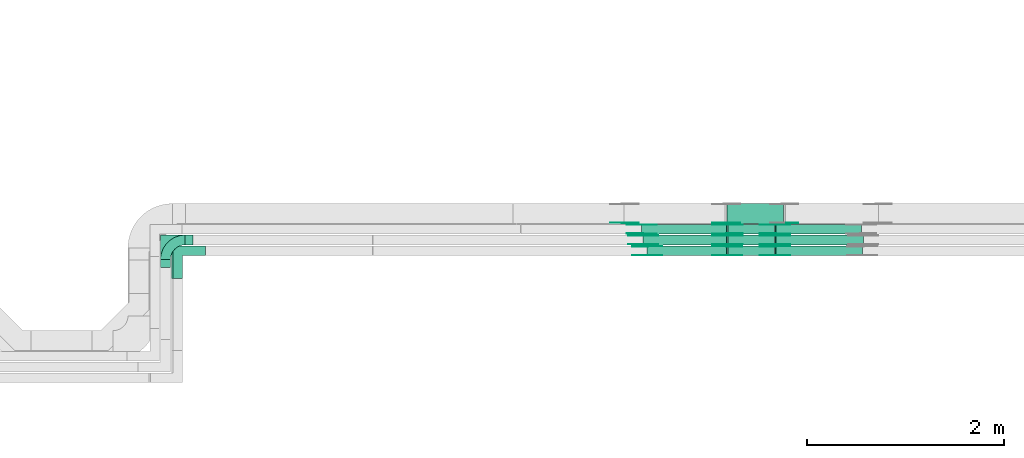
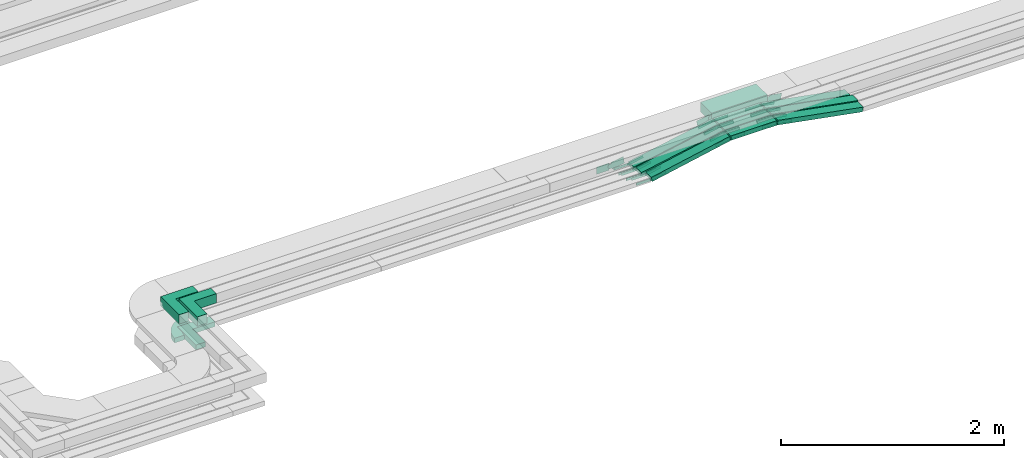
# One storey, part 21 of 33: 45 flow fittings, 10 flow segments.
"""IFC2X3 building model written with IfcOpenShell, lengths in millimetres."""

from ifc_helpers import new_model, entity, si_unit, converted_unit, derived_unit, direction, frame, frame_2d, origin, origin_2d_with_axis, place, context, subcontext, project, spatial, polyline, circle_curve, parameter, trimmed, segment, composite_curve, rectangle, outline, extrude, source, transform, mapped, material, type_object, type_shapes, element, save


model = new_model("IFC2X3")

# Units and contexts
model_context = context("Model", 3, precision=0.01, world=origin(), true_north=direction((6.12303176911189e-17, 1.0)))
body_context = subcontext(model_context, "Body", "Model", "MODEL_VIEW")
ifc_project = project(units=[si_unit("LENGTHUNIT", "METRE", prefix="MILLI"), si_unit("AREAUNIT", "SQUARE_METRE"), si_unit("VOLUMEUNIT", "CUBIC_METRE"), converted_unit("PLANEANGLEUNIT", "DEGREE", entity("IfcRatioMeasure", 0.0174532925199433), si_unit("PLANEANGLEUNIT", "RADIAN"), dimensions=[0, 0, 0, 0, 0, 0, 0]), si_unit("MASSUNIT", "GRAM", prefix="KILO"), derived_unit("MASSDENSITYUNIT", [(si_unit("MASSUNIT", "GRAM", prefix="KILO"), 1), (si_unit("LENGTHUNIT", "METRE"), -3)]), derived_unit("MOMENTOFINERTIAUNIT", [(si_unit("LENGTHUNIT", "METRE"), 4)]), si_unit("TIMEUNIT", "SECOND"), si_unit("FREQUENCYUNIT", "HERTZ"), si_unit("THERMODYNAMICTEMPERATUREUNIT", "DEGREE_CELSIUS"), derived_unit("THERMALTRANSMITTANCEUNIT", [(si_unit("MASSUNIT", "GRAM", prefix="KILO"), 1), (si_unit("THERMODYNAMICTEMPERATUREUNIT", "KELVIN"), -1), (si_unit("TIMEUNIT", "SECOND"), -3)]), derived_unit("VOLUMETRICFLOWRATEUNIT", [(si_unit("LENGTHUNIT", "METRE"), 3), (si_unit("TIMEUNIT", "SECOND"), -1)]), derived_unit("MASSFLOWRATEUNIT", [(si_unit("MASSUNIT", "GRAM", prefix="KILO"), 1), (si_unit("TIMEUNIT", "SECOND"), -1)]), derived_unit("ROTATIONALFREQUENCYUNIT", [(si_unit("TIMEUNIT", "SECOND"), -1)]), si_unit("ELECTRICCURRENTUNIT", "AMPERE"), si_unit("ELECTRICVOLTAGEUNIT", "VOLT"), si_unit("POWERUNIT", "WATT"), si_unit("FORCEUNIT", "NEWTON", prefix="KILO"), si_unit("ILLUMINANCEUNIT", "LUX"), si_unit("LUMINOUSFLUXUNIT", "LUMEN"), si_unit("LUMINOUSINTENSITYUNIT", "CANDELA"), derived_unit("USERDEFINED", [(si_unit("MASSUNIT", "GRAM", prefix="KILO"), -1), (si_unit("LENGTHUNIT", "METRE"), -2), (si_unit("TIMEUNIT", "SECOND"), 3), (si_unit("LUMINOUSFLUXUNIT", "LUMEN"), 1)]), derived_unit("LINEARVELOCITYUNIT", [(si_unit("LENGTHUNIT", "METRE"), 1), (si_unit("TIMEUNIT", "SECOND"), -1)]), si_unit("PRESSUREUNIT", "PASCAL"), derived_unit("USERDEFINED", [(si_unit("LENGTHUNIT", "METRE"), -2), (si_unit("MASSUNIT", "GRAM", prefix="KILO"), 1), (si_unit("TIMEUNIT", "SECOND"), -2)]), derived_unit("LINEARFORCEUNIT", [(si_unit("MASSUNIT", "GRAM", prefix="KILO"), 1), (si_unit("LENGTHUNIT", "METRE"), 1), (si_unit("TIMEUNIT", "SECOND"), -2), (si_unit("LENGTHUNIT", "METRE"), -1)]), derived_unit("PLANARFORCEUNIT", [(si_unit("MASSUNIT", "GRAM", prefix="KILO"), 1), (si_unit("LENGTHUNIT", "METRE"), 1), (si_unit("TIMEUNIT", "SECOND"), -2), (si_unit("LENGTHUNIT", "METRE"), -2)])], contexts=[model_context])

# Site, building, storey
site_placement = place(None, frame((0.0, -0.00077364408347762, 0.0)))
site = spatial("IfcSite", under=ifc_project, at=site_placement, CompositionType="ELEMENT")
building_placement = place(site_placement, origin())
building = spatial("IfcBuilding", under=site, at=building_placement, CompositionType="ELEMENT")
storey_placement = place(building_placement, frame((0.0, 0.0, 8100.0)))
storey = spatial("IfcBuildingStorey", under=building, at=storey_placement, CompositionType="ELEMENT", Elevation=8100.0)

# Flow segments
cable_carrier_segment_type = type_object("IfcCableCarrierSegmentType", PredefinedType="CABLETRAYSEGMENT")
flow_segment_1_placement = place(storey_placement, frame((50660.6410134739, 9694.9989777832, 2713.30497735665)))
element("IfcFlowSegment", 1, at=flow_segment_1_placement, inside=storey, type_object=cable_carrier_segment_type, context=body_context, shape_type="SweptSolid", body=[
    extrude(rectangle(XDim=477.273522129145, YDim=100.000000000001, at=frame_2d((0.0, 5.40012479177676e-13), x_axis=(1.0, 0.0))), frame((238.636913060613, 50.0015440115957, 0.000818588273602927)), (0.0, 0.0, 1.0), 50.0000000000017),
])
flow_segment_2_placement = place(storey_placement, frame((50650.9575491214, 10024.9993759154, 2713.61173786445)))
element("IfcFlowSegment", 2, at=flow_segment_2_placement, inside=storey, type_object=cable_carrier_segment_type, context=body_context, shape_type="SweptSolid", body=[
    extrude(rectangle(XDim=577.431980396776, YDim=199.999999999998, at=frame_2d((4.32009983342141e-12, 0.0), x_axis=(1.0, 0.0))), frame((288.715990198384, 100.0, 0.0)), (0.0, 0.0, 1.0), 99.9999999999989),
])
flow_segment_3_placement = place(storey_placement, frame((50662.4382699219, 9914.99937591541, 2713.31163055766)))
element("IfcFlowSegment", 3, at=flow_segment_3_placement, inside=storey, type_object=cable_carrier_segment_type, context=body_context, shape_type="SweptSolid", body=[
    extrude(rectangle(XDim=475.291800517506, YDim=99.9999999999989, at=origin_2d_with_axis()), frame((237.645900258753, 50.0, 0.0)), (0.0, 0.0, 1.0), 50.0000000000016),
])
flow_segment_4_placement = place(storey_placement, frame((50661.2573309693, 9804.99937591543, 2713.54019628628)))
element("IfcFlowSegment", 4, at=flow_segment_4_placement, inside=storey, type_object=cable_carrier_segment_type, context=body_context, shape_type="SweptSolid", body=[
    extrude(rectangle(XDim=476.37052042903, YDim=99.9999999999989, at=origin_2d_with_axis()), frame((238.185260214515, 50.0, 0.0), z_axis=(0.0, 0.0, 1.0), x_axis=(-1.0, 0.0, 0.0)), (0.0, 0.0, 1.0), 50.0000000000016),
])
flow_segment_5_placement = place(storey_placement, frame((49839.4010757259, 9695.00046998201, 2547.96021925731)))
element("IfcFlowSegment", 5, at=flow_segment_5_placement, inside=storey, type_object=cable_carrier_segment_type, context=body_context, shape_type="SweptSolid", body=[
    extrude(rectangle(XDim=50.0000000000023, YDim=100.000000000001, at=frame_2d((0.0, 5.43565192856477e-13), x_axis=(1.0, 0.0))), frame((5.00126271690856, 50.00037989648, 24.4954151198667), z_axis=(0.979786827050049, 0.0, 0.200044428913172), x_axis=(-0.200044428890075, 1.51960900459464e-05, 0.979786826936922)), (0.0, 0.0, 1.0), 825.136376037674),
])
flow_segment_6_placement = place(storey_placement, frame((51140.6281172227, 9694.99937591542, 2549.41535615934)))
element("IfcFlowSegment", 6, at=flow_segment_6_placement, inside=storey, type_object=cable_carrier_segment_type, context=body_context, shape_type="SweptSolid", body=[
    extrude(rectangle(XDim=50.0000000000012, YDim=100.000000000001, at=frame_2d((0.0, -1.08357767203415e-12), x_axis=(1.0, 0.0))), frame((4.56396664450065, 50.0, 188.220535018025), z_axis=(0.983194962125325, 0.0, -0.182558665780022), x_axis=(0.182558665780022, 0.0, 0.983194962125325)), (0.0, 0.0, 1.0), 896.373011194787),
])
flow_segment_7_placement = place(storey_placement, frame((49799.866783238, 9804.99937591543, 2547.51129297495)))
element("IfcFlowSegment", 7, at=flow_segment_7_placement, inside=storey, type_object=cable_carrier_segment_type, context=body_context, shape_type="SweptSolid", body=[
    extrude(rectangle(XDim=49.9999999999987, YDim=99.9999999999989, at=origin_2d_with_axis()), frame((4.79033535033332, 50.0, 24.5367619548982), z_axis=(0.981470478195865, 0.0, 0.191613414013684), x_axis=(-0.191613414013684, 0.0, 0.981470478195865)), (0.0, 0.0, 1.0), 865.091688195415),
])
flow_segment_8_placement = place(storey_placement, frame((51140.327569371, 9804.99937591543, 2551.08518892179)))
element("IfcFlowSegment", 8, at=flow_segment_8_placement, inside=storey, type_object=cable_carrier_segment_type, context=body_context, shape_type="SweptSolid", body=[
    extrude(rectangle(XDim=50.0000000000008, YDim=99.9999999999989, at=frame_2d((0.0, 0.0), x_axis=(0.0, 1.0))), frame((4.47414157658034, 50.0, 186.807845992506), z_axis=(0.983855320382255, 0.0, -0.178965663062864), x_axis=(0.0, 1.0, 0.0)), (0.0, 0.0, 1.0), 906.383158684558),
])
flow_segment_9_placement = place(storey_placement, frame((49784.864005538, 9914.99937591541, 2546.09274625035)))
element("IfcFlowSegment", 9, at=flow_segment_9_placement, inside=storey, type_object=cable_carrier_segment_type, context=body_context, shape_type="SweptSolid", body=[
    extrude(rectangle(XDim=50.0000000000003, YDim=99.9999999999989, at=origin_2d_with_axis()), frame((4.7359862940918, 50.0, 24.547310113782), z_axis=(0.981892404551273, 0.0, 0.189439451763671), x_axis=(-0.189439451763671, 0.0, 0.981892404551273)), (0.0, 0.0, 1.0), 881.321250243893),
])
flow_segment_10_placement = place(storey_placement, frame((51140.4451131751, 9914.99937591541, 2550.9680207194)))
element("IfcFlowSegment", 10, at=flow_segment_10_placement, inside=storey, type_object=cable_carrier_segment_type, context=body_context, shape_type="SweptSolid", body=[
    extrude(rectangle(XDim=50.0000000000006, YDim=99.9999999999989, at=frame_2d((0.0, 0.0), x_axis=(0.0, 1.0))), frame((4.57453998484662, 50.0, 186.671002044407), z_axis=(0.983116338122434, 0.0, -0.182981599393862), x_axis=(0.0, 1.0, 0.0)), (0.0, 0.0, 1.0), 885.843681158498),
])

# Flow fittings
ifc_material_1 = material()
cable_carrier_fitting_type_1 = type_object("IfcCableCarrierFittingType", Name="470_DKC_F5_Mesh horizontal angle:At right angles", PredefinedType="NOTDEFINED", material=ifc_material_1)
shared_shape_1 = source(origin(), body_context, "Body", "SweptSolid", [
    extrude(outline(polyline([(-143.333333333335, -143.333333333332), (186.666666666646, -143.333333333332), (186.666666666652, -43.3333333333317), (-43.3333333333294, -43.3333333333373), (-43.3333333333166, 186.666666666663), (-143.333333333317, 186.666666666669), (-143.333333333335, -143.333333333332)])), frame((-93.3333333333341, 93.3333333333192, -25.0), z_axis=(0.0, 0.0, 1.0), x_axis=(0.0, 1.0, 0.0)), (0.0, 0.0, 1.0), 51.9999999999999),
])
type_shapes(cable_carrier_fitting_type_1, [shared_shape_1])
flow_fitting_1_placement = place(storey_placement, frame((45049.8958236255, 9745.00084987847, 2571.66940793271), z_axis=(0.0, 0.0, 1.0), x_axis=(-1.0, 0.0, 0.0)))
element("IfcFlowFitting", 11, at=flow_fitting_1_placement, inside=storey, type_object=cable_carrier_fitting_type_1, material=ifc_material_1, Name="470_DKC_F5_Mesh horizontal angle:At right angles", ObjectType="470_DKC_F5_Mesh horizontal angle:At right angles", context=body_context, shape_type="MappedRepresentation", body=[
    mapped(shared_shape_1, transform((0.0, 0.0, 0.0), scale=1.0)),
])
cable_carrier_fitting_type_2 = type_object("IfcCableCarrierFittingType", Name="470_DKC_F5_Mesh horizontal angle:At right angles", PredefinedType="NOTDEFINED", material=ifc_material_1)
shared_shape_2 = source(origin(), body_context, "Body", "SweptSolid", [
    extrude(outline(polyline([(-143.333333333335, -143.333333333332), (186.666666666646, -143.333333333332), (186.666666666652, -43.3333333333317), (-43.3333333333294, -43.3333333333373), (-43.3333333333166, 186.666666666663), (-143.333333333317, 186.666666666669), (-143.333333333335, -143.333333333332)])), frame((-93.3333333333341, 93.3333333333192, -50.0), z_axis=(0.0, 0.0, 1.0), x_axis=(0.0, 1.0, 0.0)), (0.0, 0.0, 1.0), 102.0),
])
type_shapes(cable_carrier_fitting_type_2, [shared_shape_2])
for number, where, z_axis, x_axis, name in (
    (12, (44939.3895051674, 9854.99937591543, 2850.01096864734), (2.17578588737003e-05, 0.0, 1.0), (-1.0, 0.0, 2.17578588737003e-05), "470_DKC_F5_Mesh horizontal angle:At right angles"),
    (13, (45064.8958232878, 9745.00067454254, 2849.2813532093), (4.69987070140133e-07, 0.0, 1.0), (-1.0, 0.0, 4.69987070140133e-07), "470_DKC_F5_Mesh horizontal angle:At right angles"),
):
    element("IfcFlowFitting", number, at=place(storey_placement, frame(where, z_axis=z_axis, x_axis=x_axis)), inside=storey, type_object=cable_carrier_fitting_type_2, material=ifc_material_1, Name=name, ObjectType="470_DKC_F5_Mesh horizontal angle:At right angles", context=body_context, shape_type="MappedRepresentation", body=[
        mapped(shared_shape_2, transform((0.0, 0.0, 0.0), scale=1.0)),
    ])
cable_carrier_fitting_type_3 = type_object("IfcCableCarrierFittingType", Name="470_DKC_S5_Variable Angle Elbow 0-45:-", PredefinedType="NOTDEFINED", material=ifc_material_1)
shared_shape_3 = source(origin(), body_context, "Body", "SweptSolid", [
    extrude(outline(composite_curve([segment(polyline([(-100.750000000001, -150.25), (-99.7499999999994, -150.25)]), True, "CONTINUOUS"), segment(trimmed(circle_curve(frame_2d((-99.7499999999997, 99.7499999999995), x_axis=(0.0, -1.0)), 250.0), [parameter(0.0)], [parameter(90.0000000000001)], True, "PARAMETER"), True, "CONTINUOUS"), segment(polyline([(150.25, 99.75), (150.25, 100.749999999999)]), True, "CONTINUOUS"), segment(polyline([(150.25, 100.749999999999), (50.25, 100.75)]), True, "CONTINUOUS"), segment(polyline([(50.25, 100.75), (50.25, 99.7499999999998)]), True, "CONTINUOUS"), segment(trimmed(circle_curve(frame_2d((-99.7499999999997, 99.7499999999995), x_axis=(0.0, -1.0)), 150.0), [parameter(0.0)], [parameter(90.0000000000001)], True, "PARAMETER"), False, "CONTINUOUS"), segment(polyline([(-99.7499999999994, -50.2500000000003), (-100.750000000001, -50.2500000000003)]), True, "CONTINUOUS"), segment(polyline([(-100.750000000001, -50.2500000000003), (-100.750000000001, -150.25)]), True, "CONTINUOUS")], self_intersect=False)), frame((-100.249999999991, 100.249999999992, -25.0)), (0.0, 0.0, 1.0), 49.9999999999997),
])
type_shapes(cable_carrier_fitting_type_3, [shared_shape_3])
flow_fitting_2_placement = place(storey_placement, frame((44939.3895051674, 9854.99937591542, 2571.31908538351), z_axis=(0.0, 0.0, 1.0), x_axis=(-1.0, 0.0, 0.0)))
element("IfcFlowFitting", 14, at=flow_fitting_2_placement, inside=storey, type_object=cable_carrier_fitting_type_3, material=ifc_material_1, Name="470_DKC_S5_Variable Angle Elbow 0-45:-", ObjectType="470_DKC_S5_Variable Angle Elbow 0-45:-", context=body_context, shape_type="MappedRepresentation", body=[
    mapped(shared_shape_3, transform((0.0, 0.0, 0.0), scale=1.0)),
])
ifc_material_2 = material(Name="G")
cable_carrier_fitting_type_4 = type_object("IfcCableCarrierFittingType", PredefinedType="NOTDEFINED", material=ifc_material_2)
shared_shape_4 = source(origin(), body_context, "Body", "SweptSolid", [
    extrude(outline(composite_curve([segment(trimmed(circle_curve(frame_2d((-44.5901162790698, 0.0), x_axis=(1.0, 0.0)), 12.5), [parameter(90.0000000000007)], [parameter(270.0)], True, "PARAMETER"), True, "CONTINUOUS"), segment(polyline([(-44.5901162790697, -12.5), (-33.0901162790698, -12.5)]), True, "CONTINUOUS"), segment(polyline([(-33.0901162790698, -12.5), (-31.2296511627907, -14.5)]), True, "CONTINUOUS"), segment(polyline([(-31.2296511627907, -14.5), (108.90988372093, -14.5)]), True, "CONTINUOUS"), segment(polyline([(108.90988372093, -14.5), (108.90988372093, 14.5)]), True, "CONTINUOUS"), segment(polyline([(108.90988372093, 14.5), (-31.2296511627907, 14.5)]), True, "CONTINUOUS"), segment(polyline([(-31.2296511627907, 14.5), (-33.0901162790698, 12.5)]), True, "CONTINUOUS"), segment(polyline([(-33.0901162790698, 12.5), (-44.5901162790699, 12.5)]), True, "CONTINUOUS")], self_intersect=False)), frame((44.5901162790698, 0.0, 0.0), z_axis=(0.0, 0.0, -1.0), x_axis=(1.0, 0.0, 0.0)), (0.0, 0.0, -1.0), 2.0),
])
type_shapes(cable_carrier_fitting_type_4, [shared_shape_4])
for number, where, z_axis, x_axis in (
    (15, (49840.5515223138, 9699.54084986832, 2571.6694079327), (0.0, -1.0, 0.0), (0.979786827050029, 0.0, 0.200044428913269)),
    (16, (50656.7107681397, 9699.54084987357, 2738.3064727923), (-3.03989314942444e-06, -1.0, 1.48889288550001e-05), (-0.979786827054556, 0.0, -0.200044428891096)),
    (17, (51141.584357233, 9790.45937591928, 2738.30654020205), (3.03989318177189e-06, 1.0, 1.63717654735008e-05), (0.983194962125356, 0.0, -0.182558665779853)),
    (18, (50657.4529545895, 9809.53937590527, 2738.54019628629), (0.0, -1.0, 0.0), (-0.981470478195842, 0.0, -0.191613414013801)),
    (19, (49800.9232354835, 9809.53937590527, 2571.3190853835), (0.0, -1.0, 0.0), (0.981470478195842, 0.0, 0.191613414013801)),
    (20, (51141.243971725, 9900.45937592559, 2738.54019628629), (0.0, 1.0, 0.0), (0.983855320382267, 0.0, -0.178965663062798)),
    (21, (50658.6663010256, 9919.53937590525, 2738.31163055767), (0.0, -1.0, 0.0), (-0.9818924045513, 0.0, -0.189439451763528)),
    (22, (49785.8963242226, 9919.53937590525, 2569.92549664433), (0.0, -1.0, 0.0), (0.9818924045513, 0.0, 0.189439451763528)),
    (23, (51141.4058924678, 10010.4593759256, 2738.31163055767), (0.0, 1.0, 0.0), (0.98311633812243, 0.0, -0.182981599393884)),
):
    element("IfcFlowFitting", number, at=place(storey_placement, frame(where, z_axis=z_axis, x_axis=x_axis)), inside=storey, type_object=cable_carrier_fitting_type_4, material=ifc_material_2, context=body_context, shape_type="MappedRepresentation", body=[
        mapped(shared_shape_4, transform((0.0, 0.0, 0.0), scale=1.0)),
    ])
cable_carrier_fitting_type_5 = type_object("IfcCableCarrierFittingType", PredefinedType="NOTDEFINED", material=ifc_material_2)
shared_shape_5 = source(origin(), body_context, "Body", "SweptSolid", [
    extrude(outline(composite_curve([segment(trimmed(circle_curve(frame_2d((-44.5901162790697, 0.0), x_axis=(1.0, 0.0)), 12.5), [parameter(90.0000000000007)], [parameter(270.0)], True, "PARAMETER"), True, "CONTINUOUS"), segment(polyline([(-44.5901162790697, -12.5), (-33.0901162790697, -12.5)]), True, "CONTINUOUS"), segment(polyline([(-33.0901162790697, -12.5), (-31.2296511627907, -14.5)]), True, "CONTINUOUS"), segment(polyline([(-31.2296511627907, -14.5), (108.90988372093, -14.5)]), True, "CONTINUOUS"), segment(polyline([(108.90988372093, -14.5), (108.90988372093, 14.5)]), True, "CONTINUOUS"), segment(polyline([(108.90988372093, 14.5), (-31.2296511627907, 14.5)]), True, "CONTINUOUS"), segment(polyline([(-31.2296511627907, 14.5), (-33.0901162790698, 12.5)]), True, "CONTINUOUS"), segment(polyline([(-33.0901162790698, 12.5), (-44.5901162790699, 12.5)]), True, "CONTINUOUS")], self_intersect=False)), frame((44.5901162790697, 0.0, 0.0)), (0.0, 0.0, 1.0), 2.0),
])
type_shapes(cable_carrier_fitting_type_5, [shared_shape_5])
for number, where, z_axis, x_axis in (
    (24, (49840.5515223138, 9790.46084988864, 2571.66940793269), (0.0, 1.0, 0.0), (0.979786827050029, 0.0, 0.200044428913269)),
    (25, (50656.7110445268, 9790.46084988339, 2738.30511909089), (3.03989313613108e-06, 1.0, -1.48889288577142e-05), (-0.979786827054556, 0.0, -0.200044428891096)),
    (26, (51141.5840808459, 9699.53937591157, 2738.30505168114), (-3.0398931684323e-06, -1.0, -1.63717654759777e-05), (0.983194962125356, 0.0, -0.182558665779853)),
    (27, (50657.4529545895, 9900.45937592559, 2738.54019628629), (0.0, 1.0, 0.0), (-0.981470478195842, 0.0, -0.191613414013801)),
    (28, (49800.9232354835, 9900.45937592559, 2571.3190853835), (0.0, 1.0, 0.0), (0.981470478195842, 0.0, 0.191613414013801)),
    (29, (51141.243971725, 9809.53937590527, 2738.54019628629), (0.0, -1.0, 0.0), (0.983855320382267, 0.0, -0.178965663062798)),
    (30, (50658.6663010256, 10010.4593759256, 2738.31163055767), (0.0, 1.0, 0.0), (-0.9818924045513, 0.0, -0.189439451763528)),
    (31, (49785.8963242226, 10010.4593759256, 2569.92549664433), (0.0, 1.0, 0.0), (0.9818924045513, 0.0, 0.189439451763528)),
    (32, (51141.4058924678, 9919.53937590525, 2738.31163055767), (0.0, -1.0, 0.0), (0.98311633812243, 0.0, -0.182981599393884)),
):
    element("IfcFlowFitting", number, at=place(storey_placement, frame(where, z_axis=z_axis, x_axis=x_axis)), inside=storey, type_object=cable_carrier_fitting_type_5, material=ifc_material_2, context=body_context, shape_type="MappedRepresentation", body=[
        mapped(shared_shape_5, transform((0.0, 0.0, 0.0), scale=1.0)),
    ])
cable_carrier_fitting_type_6 = type_object("IfcCableCarrierFittingType", PredefinedType="NOTDEFINED", material=ifc_material_2)
shared_shape_6 = source(origin(), body_context, "Body", "SweptSolid", [
    extrude(outline(composite_curve([segment(trimmed(circle_curve(frame_2d((-44.5901162790698, 0.0), x_axis=(1.0, 0.0)), 12.5), [parameter(90.0000000000007)], [parameter(270.0)], True, "PARAMETER"), True, "CONTINUOUS"), segment(polyline([(-44.5901162790697, -12.5), (-33.0901162790698, -12.5)]), True, "CONTINUOUS"), segment(polyline([(-33.0901162790698, -12.5), (-31.2296511627907, -14.5)]), True, "CONTINUOUS"), segment(polyline([(-31.2296511627907, -14.5), (108.90988372093, -14.5)]), True, "CONTINUOUS"), segment(polyline([(108.90988372093, -14.5), (108.90988372093, 14.5)]), True, "CONTINUOUS"), segment(polyline([(108.90988372093, 14.5), (-31.2296511627907, 14.5)]), True, "CONTINUOUS"), segment(polyline([(-31.2296511627907, 14.5), (-33.0901162790698, 12.5)]), True, "CONTINUOUS"), segment(polyline([(-33.0901162790698, 12.5), (-44.5901162790699, 12.5)]), True, "CONTINUOUS")], self_intersect=False)), frame((44.5901162790698, 0.0, 0.0), z_axis=(0.0, 0.0, -1.0), x_axis=(1.0, 0.0, 0.0)), (0.0, 0.0, -1.0), 2.0),
])
type_shapes(cable_carrier_fitting_type_6, [shared_shape_6])
for number, where, z_axis, x_axis in (
    (33, (49840.5515223139, 9788.46084988864, 2571.6694079327), (0.0, 1.0, 0.0), (-1.0, 0.0, 0.0)),
    (34, (50656.711038447, 9788.46084988362, 2738.30514886874), (3.03989316299203e-06, 1.0, -1.48889288550001e-05), (1.0, -3.03989316332888e-06, 0.0)),
    (35, (51141.5840869257, 9701.53937591129, 2738.30508442466), (-3.03989319533949e-06, -1.0, -1.63717654735008e-05), (-1.0, 3.03989319574678e-06, 0.0)),
    (36, (50657.4529545895, 9898.45937592559, 2738.54019628629), (0.0, 1.0, 0.0), (1.0, 0.0, 0.0)),
    (37, (49800.9232354836, 9898.45937592559, 2571.3190853835), (0.0, 1.0, 0.0), (-1.0, 0.0, 0.0)),
    (38, (51141.243971725, 9811.53937590527, 2738.54019628629), (0.0, -1.0, 0.0), (-1.0, 0.0, 0.0)),
    (39, (50658.6663010256, 10008.4593759256, 2738.31163055767), (0.0, 1.0, 0.0), (1.0, 0.0, 0.0)),
    (40, (49785.8963242226, 10008.4593759256, 2569.92549664434), (0.0, 1.0, 0.0), (-1.0, 0.0, 0.0)),
    (41, (51141.4058924678, 9921.53937590525, 2738.31163055767), (0.0, -1.0, 0.0), (-1.0, 0.0, 0.0)),
):
    element("IfcFlowFitting", number, at=place(storey_placement, frame(where, z_axis=z_axis, x_axis=x_axis)), inside=storey, type_object=cable_carrier_fitting_type_6, material=ifc_material_2, context=body_context, shape_type="MappedRepresentation", body=[
        mapped(shared_shape_6, transform((0.0, 0.0, 0.0), scale=1.0)),
    ])
cable_carrier_fitting_type_7 = type_object("IfcCableCarrierFittingType", PredefinedType="NOTDEFINED", material=ifc_material_2)
shared_shape_7 = source(origin(), body_context, "Body", "SweptSolid", [
    extrude(outline(composite_curve([segment(trimmed(circle_curve(frame_2d((-44.5901162790697, 0.0), x_axis=(1.0, 0.0)), 12.5), [parameter(90.0000000000007)], [parameter(270.0)], True, "PARAMETER"), True, "CONTINUOUS"), segment(polyline([(-44.5901162790697, -12.5), (-33.0901162790697, -12.5)]), True, "CONTINUOUS"), segment(polyline([(-33.0901162790697, -12.5), (-31.2296511627907, -14.5)]), True, "CONTINUOUS"), segment(polyline([(-31.2296511627907, -14.5), (108.90988372093, -14.5)]), True, "CONTINUOUS"), segment(polyline([(108.90988372093, -14.5), (108.90988372093, 14.5)]), True, "CONTINUOUS"), segment(polyline([(108.90988372093, 14.5), (-31.2296511627907, 14.5)]), True, "CONTINUOUS"), segment(polyline([(-31.2296511627907, 14.5), (-33.0901162790698, 12.5)]), True, "CONTINUOUS"), segment(polyline([(-33.0901162790698, 12.5), (-44.5901162790699, 12.5)]), True, "CONTINUOUS")], self_intersect=False)), frame((44.5901162790697, 0.0, 0.0)), (0.0, 0.0, 1.0), 2.0),
])
type_shapes(cable_carrier_fitting_type_7, [shared_shape_7])
for number, where, z_axis, x_axis in (
    (42, (49840.5515223139, 9701.54084986833, 2571.6694079327), (0.0, -1.0, 0.0), (-1.0, 0.0, 0.0)),
    (43, (50656.7107742195, 9701.54084987335, 2738.30644301443), (-3.03989313585684e-06, -1.0, 1.48889288685677e-05), (1.0, -3.03989313619369e-06, 0.0)),
    (44, (51141.5843511532, 9788.45937591955, 2738.30650745851), (3.03989316820429e-06, 1.0, 1.63717654870684e-05), (-1.0, 3.03989316861159e-06, 0.0)),
    (45, (50657.4529545895, 9811.53937590527, 2738.54019628628), (0.0, -1.0, 0.0), (1.0, 0.0, 0.0)),
    (46, (49800.9232354836, 9811.53937590527, 2571.3190853835), (0.0, -1.0, 0.0), (-1.0, 0.0, 0.0)),
    (47, (51141.243971725, 9898.45937592558, 2738.54019628628), (0.0, 1.0, 0.0), (-1.0, 0.0, 0.0)),
    (48, (50658.6663010256, 9921.53937590525, 2738.31163055767), (0.0, -1.0, 0.0), (1.0, 0.0, 0.0)),
    (49, (49785.8963242226, 9921.53937590525, 2569.92549664434), (0.0, -1.0, 0.0), (-1.0, 0.0, 0.0)),
    (50, (51141.4058924678, 10008.4593759256, 2738.31163055767), (0.0, 1.0, 0.0), (-1.0, 0.0, 0.0)),
):
    element("IfcFlowFitting", number, at=place(storey_placement, frame(where, z_axis=z_axis, x_axis=x_axis)), inside=storey, type_object=cable_carrier_fitting_type_7, material=ifc_material_2, context=body_context, shape_type="MappedRepresentation", body=[
        mapped(shared_shape_7, transform((0.0, 0.0, 0.0), scale=1.0)),
    ])
cable_carrier_fitting_type_8 = type_object("IfcCableCarrierFittingType", PredefinedType="NOTDEFINED", material=ifc_material_2)
shared_shape_8 = source(origin(), body_context, "Body", "SweptSolid", [
    extrude(outline(composite_curve([segment(trimmed(circle_curve(frame_2d((-41.4651162790697, 0.0), x_axis=(1.0, 0.0)), 25.0), [parameter(90.0000000000007)], [parameter(270.0)], True, "PARAMETER"), True, "CONTINUOUS"), segment(polyline([(-41.4651162790697, -25.0), (-29.9651162790697, -25.0)]), True, "CONTINUOUS"), segment(polyline([(-29.9651162790697, -25.0), (-28.1046511627907, -38.5)]), True, "CONTINUOUS"), segment(polyline([(-28.1046511627907, -38.5), (99.5348837209303, -38.5)]), True, "CONTINUOUS"), segment(polyline([(99.5348837209303, -38.5), (99.5348837209303, 38.5)]), True, "CONTINUOUS"), segment(polyline([(99.5348837209303, 38.5), (-28.1046511627907, 38.5)]), True, "CONTINUOUS"), segment(polyline([(-28.1046511627907, 38.5), (-29.9651162790697, 25.0)]), True, "CONTINUOUS"), segment(polyline([(-29.9651162790697, 25.0), (-41.46511627907, 25.0)]), True, "CONTINUOUS")], self_intersect=False)), frame((41.4651162790697, 0.0, 0.0), z_axis=(0.0, 0.0, -1.0), x_axis=(1.0, 0.0, 0.0)), (0.0, 0.0, -1.0), 2.0),
])
type_shapes(cable_carrier_fitting_type_8, [shared_shape_8])
flow_fitting_3_placement = place(storey_placement, frame((49608.2757950546, 10029.5393759052, 2597.39498136107), z_axis=(0.0, -1.0, 0.0), x_axis=(0.987405642693208, 0.0, 0.15820902874872)))
element("IfcFlowFitting", 51, at=flow_fitting_3_placement, inside=storey, type_object=cable_carrier_fitting_type_8, material=ifc_material_2, context=body_context, shape_type="MappedRepresentation", body=[
    mapped(shared_shape_8, transform((0.0, 0.0, 0.0), scale=1.0)),
])
cable_carrier_fitting_type_9 = type_object("IfcCableCarrierFittingType", PredefinedType="NOTDEFINED", material=ifc_material_2)
shared_shape_9 = source(origin(), body_context, "Body", "SweptSolid", [
    extrude(outline(composite_curve([segment(trimmed(circle_curve(frame_2d((-41.4651162790697, 0.0), x_axis=(1.0, 0.0)), 25.0), [parameter(90.0000000000007)], [parameter(270.0)], True, "PARAMETER"), True, "CONTINUOUS"), segment(polyline([(-41.4651162790697, -25.0), (-29.9651162790697, -25.0)]), True, "CONTINUOUS"), segment(polyline([(-29.9651162790697, -25.0), (-28.1046511627907, -38.5)]), True, "CONTINUOUS"), segment(polyline([(-28.1046511627907, -38.5), (99.5348837209303, -38.5)]), True, "CONTINUOUS"), segment(polyline([(99.5348837209303, -38.5), (99.5348837209303, 38.5)]), True, "CONTINUOUS"), segment(polyline([(99.5348837209303, 38.5), (-28.1046511627907, 38.5)]), True, "CONTINUOUS"), segment(polyline([(-28.1046511627907, 38.5), (-29.9651162790697, 25.0)]), True, "CONTINUOUS"), segment(polyline([(-29.9651162790697, 25.0), (-41.46511627907, 25.0)]), True, "CONTINUOUS")], self_intersect=False)), frame((41.4651162790697, 0.0, 0.0)), (0.0, 0.0, 1.0), 2.0),
])
type_shapes(cable_carrier_fitting_type_9, [shared_shape_9])
for number, where, z_axis, x_axis in (
    (52, (50645.658835578, 10029.5393759052, 2763.61173786447), (0.0, -1.0, 0.0), (1.0, 0.0, 0.0)),
    (53, (51233.9754297485, 10029.5393759052, 2763.61173786447), (0.0, -1.0, 0.0), (0.985679085688948, 0.0, -0.168631966232386)),
):
    element("IfcFlowFitting", number, at=place(storey_placement, frame(where, z_axis=z_axis, x_axis=x_axis)), inside=storey, type_object=cable_carrier_fitting_type_9, material=ifc_material_2, context=body_context, shape_type="MappedRepresentation", body=[
        mapped(shared_shape_9, transform((0.0, 0.0, 0.0), scale=1.0)),
    ])
cable_carrier_fitting_type_10 = type_object("IfcCableCarrierFittingType", PredefinedType="NOTDEFINED", material=ifc_material_2)
shared_shape_10 = source(origin(), body_context, "Body", "SweptSolid", [
    extrude(outline(composite_curve([segment(trimmed(circle_curve(frame_2d((-41.4651162790697, 0.0), x_axis=(1.0, 0.0)), 25.0), [parameter(90.0000000000007)], [parameter(270.0)], True, "PARAMETER"), True, "CONTINUOUS"), segment(polyline([(-41.4651162790697, -25.0), (-29.9651162790697, -25.0)]), True, "CONTINUOUS"), segment(polyline([(-29.9651162790697, -25.0), (-28.1046511627907, -38.5)]), True, "CONTINUOUS"), segment(polyline([(-28.1046511627907, -38.5), (99.5348837209303, -38.5)]), True, "CONTINUOUS"), segment(polyline([(99.5348837209303, -38.5), (99.5348837209303, 38.5)]), True, "CONTINUOUS"), segment(polyline([(99.5348837209303, 38.5), (-28.1046511627907, 38.5)]), True, "CONTINUOUS"), segment(polyline([(-28.1046511627907, 38.5), (-29.9651162790697, 25.0)]), True, "CONTINUOUS"), segment(polyline([(-29.9651162790697, 25.0), (-41.46511627907, 25.0)]), True, "CONTINUOUS")], self_intersect=False)), frame((41.4651162790697, 0.0, 0.0), z_axis=(0.0, 0.0, -1.0), x_axis=(1.0, 0.0, 0.0)), (0.0, 0.0, -1.0), 2.0),
])
type_shapes(cable_carrier_fitting_type_10, [shared_shape_10])
flow_fitting_4_placement = place(storey_placement, frame((50645.658835578, 10031.5393759052, 2763.61173786447), z_axis=(0.0, -1.0, 0.0), x_axis=(-0.987405642693216, 0.0, -0.158209028748672)))
element("IfcFlowFitting", 54, at=flow_fitting_4_placement, inside=storey, type_object=cable_carrier_fitting_type_10, material=ifc_material_2, context=body_context, shape_type="MappedRepresentation", body=[
    mapped(shared_shape_10, transform((0.0, 0.0, 0.0), scale=1.0)),
])
cable_carrier_fitting_type_11 = type_object("IfcCableCarrierFittingType", PredefinedType="NOTDEFINED", material=ifc_material_2)
shared_shape_11 = source(origin(), body_context, "Body", "SweptSolid", [
    extrude(outline(composite_curve([segment(trimmed(circle_curve(frame_2d((-41.4651162790697, 0.0), x_axis=(1.0, 0.0)), 25.0), [parameter(90.0000000000007)], [parameter(270.0)], True, "PARAMETER"), True, "CONTINUOUS"), segment(polyline([(-41.4651162790697, -25.0), (-29.9651162790697, -25.0)]), True, "CONTINUOUS"), segment(polyline([(-29.9651162790697, -25.0), (-28.1046511627907, -38.5)]), True, "CONTINUOUS"), segment(polyline([(-28.1046511627907, -38.5), (99.5348837209303, -38.5)]), True, "CONTINUOUS"), segment(polyline([(99.5348837209303, -38.5), (99.5348837209303, 38.5)]), True, "CONTINUOUS"), segment(polyline([(99.5348837209303, 38.5), (-28.1046511627907, 38.5)]), True, "CONTINUOUS"), segment(polyline([(-28.1046511627907, 38.5), (-29.9651162790697, 25.0)]), True, "CONTINUOUS"), segment(polyline([(-29.9651162790697, 25.0), (-41.46511627907, 25.0)]), True, "CONTINUOUS")], self_intersect=False)), frame((41.4651162790697, 0.0, 0.0)), (0.0, 0.0, 1.0), 2.0),
])
type_shapes(cable_carrier_fitting_type_11, [shared_shape_11])
flow_fitting_5_placement = place(storey_placement, frame((49608.2757950546, 10031.5393759052, 2597.39498136107), z_axis=(0.0, -1.0, 0.0), x_axis=(-1.0, 0.0, 0.0)))
element("IfcFlowFitting", 55, at=flow_fitting_5_placement, inside=storey, type_object=cable_carrier_fitting_type_11, material=ifc_material_2, context=body_context, shape_type="MappedRepresentation", body=[
    mapped(shared_shape_11, transform((0.0, 0.0, 0.0), scale=1.0)),
])

save(model, "model.ifc")
